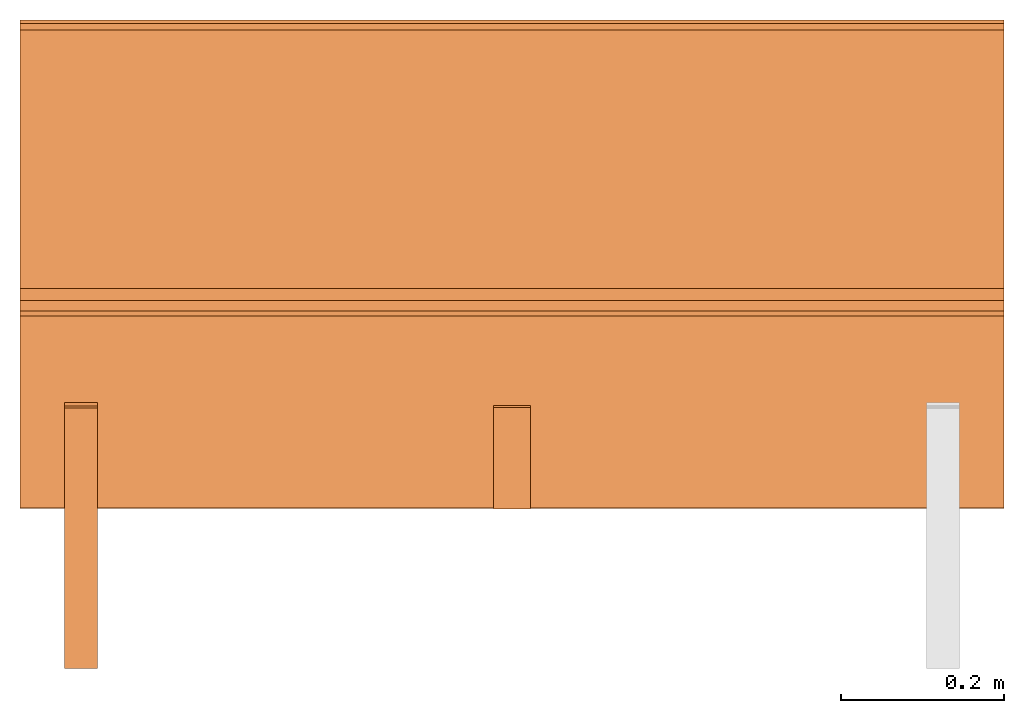
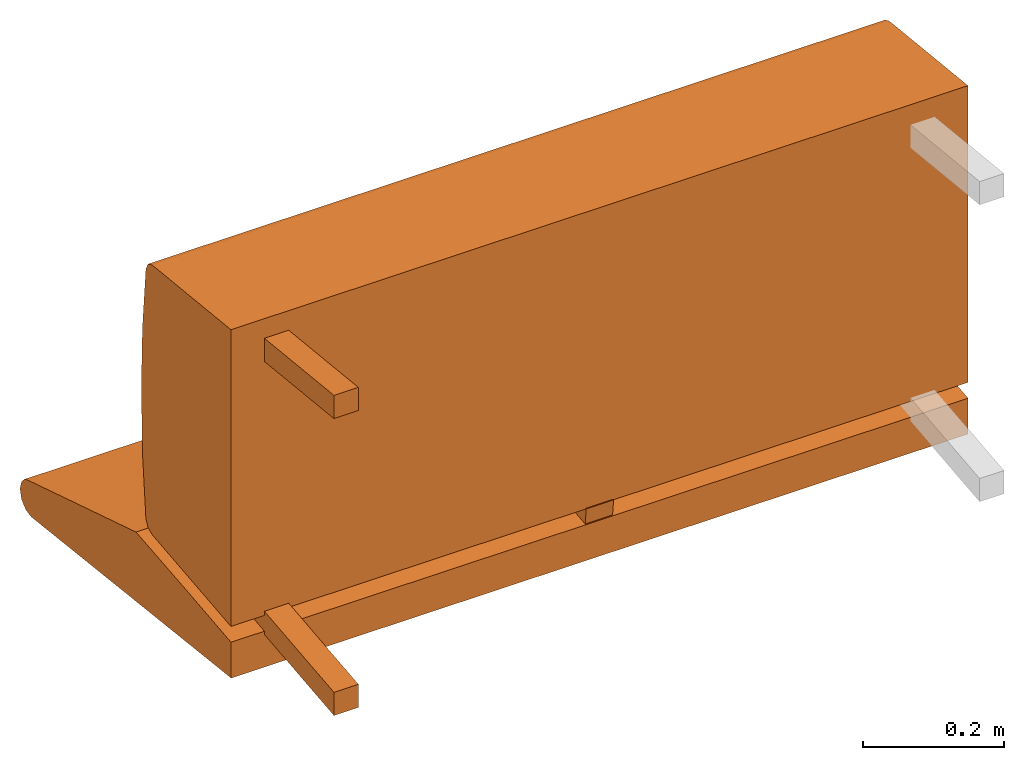
# One storey, part 1 of 2: 5 proxies, 1 element without a shape of its own.
"""IFC2X3 building model written with IfcOpenShell, lengths in metres."""

from ifc_helpers import new_model, si_unit, direction, origin_with_axes, place, context, project, spatial, faceted_brep, source, transform, mapped, element, aggregate, save


model = new_model("IFC2X3")

# Units and contexts
model_context = context("Model", 3, precision=1e-06, world=origin_with_axes(), true_north=direction((0.0, 1.0, 0.0)))
ifc_project = project(units=[si_unit("LENGTHUNIT", "METRE"), si_unit("AREAUNIT", "SQUARE_METRE"), si_unit("VOLUMEUNIT", "CUBIC_METRE")], contexts=[model_context])

# Site, building, storey
site_placement = place(None, origin_with_axes())
site = spatial("IfcSite", under=ifc_project, at=site_placement, CompositionType="ELEMENT")
building_placement = place(site_placement, origin_with_axes())
building = spatial("IfcBuilding", under=site, at=building_placement, Name="Default Building", CompositionType="ELEMENT")
storey_placement = place(building_placement, origin_with_axes())
storey = spatial("IfcBuildingStorey", under=building, at=storey_placement, Name="Default Storey", CompositionType="ELEMENT", Elevation=0.0)

# Assembly, proxies
assembly_placement = place(storey_placement, origin_with_axes())
assembly = element("IfcElementAssembly", 1, at=assembly_placement, inside=storey, AssemblyPlace="NOTDEFINED", PredefinedType="NOTDEFINED")
shared_shape_1 = source(origin_with_axes(), model_context, "Body", "Brep", [
    faceted_brep([(0.6050000190734863, 0.01804635114967823, -0.27114158868789673), (0.6050000190734863, 0.15895022451877594, -0.2573375105857849), (-0.6050000190734863, 0.01804635114967823, -0.27114158868789673), (-0.6050000190734863, 0.01804635114967823, -0.27114158868789673), (0.6050000190734863, 0.15895022451877594, -0.2573375105857849), (-0.6050000190734863, 0.15895022451877594, -0.2573375105857849), (0.6050000190734863, -0.11124149709939957, -0.28473028540611267), (0.6050000190734863, 0.01804635114967823, -0.27114158868789673), (-0.6050000190734863, -0.11124149709939957, -0.28473028540611267), (-0.6050000190734863, -0.11124149709939957, -0.28473028540611267), (0.6050000190734863, 0.01804635114967823, -0.27114158868789673), (-0.6050000190734863, 0.01804635114967823, -0.27114158868789673), (0.6050000190734863, -0.11165377497673035, -0.345802903175354), (0.6050000190734863, -0.11124149709939957, -0.28473028540611267), (-0.6050000190734863, -0.11165377497673035, -0.345802903175354), (-0.6050000190734863, -0.11165377497673035, -0.345802903175354), (0.6050000190734863, -0.11124149709939957, -0.28473028540611267), (-0.6050000190734863, -0.11124149709939957, -0.28473028540611267), (0.6050000190734863, -0.11165299266576767, -0.34598633646965027), (0.6050000190734863, -0.11165377497673035, -0.345802903175354), (-0.6050000190734863, -0.11165299266576767, -0.34598633646965027), (-0.6050000190734863, -0.11165299266576767, -0.34598633646965027), (0.6050000190734863, -0.11165377497673035, -0.345802903175354), (-0.6050000190734863, -0.11165377497673035, -0.345802903175354), (0.6050000190734863, -0.11164932698011398, -0.3461695909500122), (0.6050000190734863, -0.11165299266576767, -0.34598633646965027), (-0.6050000190734863, -0.11164932698011398, -0.3461695909500122), (-0.6050000190734863, -0.11164932698011398, -0.3461695909500122), (0.6050000190734863, -0.11165299266576767, -0.34598633646965027), (-0.6050000190734863, -0.11165299266576767, -0.34598633646965027), (0.6050000190734863, -0.11164313554763794, -0.3463243842124939), (0.6050000190734863, -0.11164932698011398, -0.3461695909500122), (-0.6050000190734863, -0.11164313554763794, -0.3463243842124939), (-0.6050000190734863, -0.11164313554763794, -0.3463243842124939), (0.6050000190734863, -0.11164932698011398, -0.3461695909500122), (-0.6050000190734863, -0.11164932698011398, -0.3461695909500122), (0.6050000190734863, -0.111635722219944, -0.34647393226623535), (0.6050000190734863, -0.11164313554763794, -0.3463243842124939), (-0.6050000190734863, -0.111635722219944, -0.34647393226623535), (-0.6050000190734863, -0.111635722219944, -0.34647393226623535), (0.6050000190734863, -0.11164313554763794, -0.3463243842124939), (-0.6050000190734863, -0.11164313554763794, -0.3463243842124939), (0.6050000190734863, -0.11160843819379807, -0.3467184603214264), (0.6050000190734863, -0.111635722219944, -0.34647393226623535), (-0.6050000190734863, -0.11160843819379807, -0.3467184603214264), (-0.6050000190734863, -0.11160843819379807, -0.3467184603214264), (0.6050000190734863, -0.111635722219944, -0.34647393226623535), (-0.6050000190734863, -0.111635722219944, -0.34647393226623535), (0.6050000190734863, 0.45686498284339905, -0.41162583231925964), (0.6050000190734863, -0.11160843819379807, -0.3467184603214264), (-0.6050000190734863, 0.45686498284339905, -0.41162583231925964), (-0.6050000190734863, 0.45686498284339905, -0.41162583231925964), (0.6050000190734863, -0.11160843819379807, -0.3467184603214264), (-0.6050000190734863, -0.11160843819379807, -0.3467184603214264), (0.6050000190734863, 0.4726467430591583, -0.40858420729637146), (0.6050000190734863, 0.45686498284339905, -0.41162583231925964), (-0.6050000190734863, 0.4726467430591583, -0.40858420729637146), (-0.6050000190734863, 0.4726467430591583, -0.40858420729637146), (0.6050000190734863, 0.45686498284339905, -0.41162583231925964), (-0.6050000190734863, 0.45686498284339905, -0.41162583231925964), (0.6050000190734863, 0.48448991775512695, -0.397742360830307), (0.6050000190734863, 0.4726467430591583, -0.40858420729637146), (-0.6050000190734863, 0.48448991775512695, -0.397742360830307), (-0.6050000190734863, 0.48448991775512695, -0.397742360830307), (0.6050000190734863, 0.4726467430591583, -0.40858420729637146), (-0.6050000190734863, 0.4726467430591583, -0.40858420729637146), (0.6050000190734863, 0.4888731837272644, -0.3822959065437317), (0.6050000190734863, 0.48448991775512695, -0.397742360830307), (-0.6050000190734863, 0.4888731837272644, -0.3822959065437317), (-0.6050000190734863, 0.4888731837272644, -0.3822959065437317), (0.6050000190734863, 0.48448991775512695, -0.397742360830307), (-0.6050000190734863, 0.48448991775512695, -0.397742360830307), (0.6050000190734863, 0.48448991775512695, -0.36684948205947876), (0.6050000190734863, 0.4888731837272644, -0.3822959065437317), (-0.6050000190734863, 0.48448991775512695, -0.36684948205947876), (-0.6050000190734863, 0.48448991775512695, -0.36684948205947876), (0.6050000190734863, 0.4888731837272644, -0.3822959065437317), (-0.6050000190734863, 0.4888731837272644, -0.3822959065437317), (0.6050000190734863, 0.47627729177474976, -0.35816749930381775), (0.6050000190734863, 0.48448991775512695, -0.36684948205947876), (-0.6050000190734863, 0.47627729177474976, -0.35816749930381775), (-0.6050000190734863, 0.47627729177474976, -0.35816749930381775), (0.6050000190734863, 0.48448991775512695, -0.36684948205947876), (-0.6050000190734863, 0.48448991775512695, -0.36684948205947876), (0.6050000190734863, 0.46825650334358215, -0.3542327880859375), (0.6050000190734863, 0.47627729177474976, -0.35816749930381775), (-0.6050000190734863, 0.46825650334358215, -0.3542327880859375), (-0.6050000190734863, 0.46825650334358215, -0.3542327880859375), (0.6050000190734863, 0.47627729177474976, -0.35816749930381775), (-0.6050000190734863, 0.47627729177474976, -0.35816749930381775), (0.6050000190734863, 0.15895022451877594, -0.2573375105857849), (0.6050000190734863, 0.46825650334358215, -0.3542327880859375), (-0.6050000190734863, 0.15895022451877594, -0.2573375105857849), (-0.6050000190734863, 0.15895022451877594, -0.2573375105857849), (0.6050000190734863, 0.46825650334358215, -0.3542327880859375), (-0.6050000190734863, 0.46825650334358215, -0.3542327880859375), (0.6050000190734863, -0.111635722219944, -0.34647393226623535), (0.6050000190734863, -0.11160843819379807, -0.3467184603214264), (0.6050000190734863, 0.01804635114967823, -0.27114158868789673), (0.6050000190734863, 0.45686498284339905, -0.41162583231925964), (0.6050000190734863, 0.46825650334358215, -0.3542327880859375), (0.6050000190734863, -0.11160843819379807, -0.3467184603214264), (0.6050000190734863, -0.11160843819379807, -0.3467184603214264), (0.6050000190734863, 0.46825650334358215, -0.3542327880859375), (0.6050000190734863, 0.15895022451877594, -0.2573375105857849), (0.6050000190734863, -0.11160843819379807, -0.3467184603214264), (0.6050000190734863, 0.15895022451877594, -0.2573375105857849), (0.6050000190734863, 0.01804635114967823, -0.27114158868789673), (0.6050000190734863, -0.11124149709939957, -0.28473028540611267), (0.6050000190734863, -0.11165377497673035, -0.345802903175354), (0.6050000190734863, 0.01804635114967823, -0.27114158868789673), (0.6050000190734863, 0.01804635114967823, -0.27114158868789673), (0.6050000190734863, -0.11165377497673035, -0.345802903175354), (0.6050000190734863, -0.11165299266576767, -0.34598633646965027), (0.6050000190734863, -0.11165299266576767, -0.34598633646965027), (0.6050000190734863, -0.11164932698011398, -0.3461695909500122), (0.6050000190734863, 0.01804635114967823, -0.27114158868789673), (0.6050000190734863, 0.01804635114967823, -0.27114158868789673), (0.6050000190734863, -0.11164932698011398, -0.3461695909500122), (0.6050000190734863, -0.11164313554763794, -0.3463243842124939), (0.6050000190734863, 0.01804635114967823, -0.27114158868789673), (0.6050000190734863, -0.11164313554763794, -0.3463243842124939), (0.6050000190734863, -0.111635722219944, -0.34647393226623535), (0.6050000190734863, 0.48448991775512695, -0.397742360830307), (0.6050000190734863, 0.4888731837272644, -0.3822959065437317), (0.6050000190734863, 0.4726467430591583, -0.40858420729637146), (0.6050000190734863, 0.4726467430591583, -0.40858420729637146), (0.6050000190734863, 0.4888731837272644, -0.3822959065437317), (0.6050000190734863, 0.48448991775512695, -0.36684948205947876), (0.6050000190734863, 0.4726467430591583, -0.40858420729637146), (0.6050000190734863, 0.48448991775512695, -0.36684948205947876), (0.6050000190734863, 0.45686498284339905, -0.41162583231925964), (0.6050000190734863, 0.45686498284339905, -0.41162583231925964), (0.6050000190734863, 0.48448991775512695, -0.36684948205947876), (0.6050000190734863, 0.47627729177474976, -0.35816749930381775), (0.6050000190734863, 0.45686498284339905, -0.41162583231925964), (0.6050000190734863, 0.47627729177474976, -0.35816749930381775), (0.6050000190734863, 0.46825650334358215, -0.3542327880859375), (-0.6050000190734863, -0.11165377497673035, -0.345802903175354), (-0.6050000190734863, -0.11124149709939957, -0.28473028540611267), (-0.6050000190734863, 0.01804635114967823, -0.27114158868789673), (-0.6050000190734863, 0.46825650334358215, -0.3542327880859375), (-0.6050000190734863, 0.45686498284339905, -0.41162583231925964), (-0.6050000190734863, 0.15895022451877594, -0.2573375105857849), (-0.6050000190734863, 0.15895022451877594, -0.2573375105857849), (-0.6050000190734863, 0.45686498284339905, -0.41162583231925964), (-0.6050000190734863, -0.11160843819379807, -0.3467184603214264), (-0.6050000190734863, 0.15895022451877594, -0.2573375105857849), (-0.6050000190734863, -0.11160843819379807, -0.3467184603214264), (-0.6050000190734863, 0.01804635114967823, -0.27114158868789673), (-0.6050000190734863, 0.01804635114967823, -0.27114158868789673), (-0.6050000190734863, -0.11160843819379807, -0.3467184603214264), (-0.6050000190734863, -0.111635722219944, -0.34647393226623535), (-0.6050000190734863, 0.01804635114967823, -0.27114158868789673), (-0.6050000190734863, -0.111635722219944, -0.34647393226623535), (-0.6050000190734863, -0.11164313554763794, -0.3463243842124939), (-0.6050000190734863, -0.11164313554763794, -0.3463243842124939), (-0.6050000190734863, -0.11164932698011398, -0.3461695909500122), (-0.6050000190734863, 0.01804635114967823, -0.27114158868789673), (-0.6050000190734863, 0.01804635114967823, -0.27114158868789673), (-0.6050000190734863, -0.11164932698011398, -0.3461695909500122), (-0.6050000190734863, -0.11165299266576767, -0.34598633646965027), (-0.6050000190734863, 0.01804635114967823, -0.27114158868789673), (-0.6050000190734863, -0.11165299266576767, -0.34598633646965027), (-0.6050000190734863, -0.11165377497673035, -0.345802903175354), (-0.6050000190734863, 0.48448991775512695, -0.36684948205947876), (-0.6050000190734863, 0.4888731837272644, -0.3822959065437317), (-0.6050000190734863, 0.48448991775512695, -0.397742360830307), (-0.6050000190734863, 0.46825650334358215, -0.3542327880859375), (-0.6050000190734863, 0.47627729177474976, -0.35816749930381775), (-0.6050000190734863, 0.45686498284339905, -0.41162583231925964), (-0.6050000190734863, 0.45686498284339905, -0.41162583231925964), (-0.6050000190734863, 0.47627729177474976, -0.35816749930381775), (-0.6050000190734863, 0.48448991775512695, -0.36684948205947876), (-0.6050000190734863, 0.45686498284339905, -0.41162583231925964), (-0.6050000190734863, 0.48448991775512695, -0.36684948205947876), (-0.6050000190734863, 0.4726467430591583, -0.40858420729637146), (-0.6050000190734863, 0.4726467430591583, -0.40858420729637146), (-0.6050000190734863, 0.48448991775512695, -0.36684948205947876), (-0.6050000190734863, 0.48448991775512695, -0.397742360830307)], [[[0, 1, 2]], [[3, 4, 5]], [[6, 7, 8]], [[9, 10, 11]], [[12, 13, 14]], [[15, 16, 17]], [[18, 19, 20]], [[21, 22, 23]], [[24, 25, 26]], [[27, 28, 29]], [[30, 31, 32]], [[33, 34, 35]], [[36, 37, 38]], [[39, 40, 41]], [[42, 43, 44]], [[45, 46, 47]], [[48, 49, 50]], [[51, 52, 53]], [[54, 55, 56]], [[57, 58, 59]], [[60, 61, 62]], [[63, 64, 65]], [[66, 67, 68]], [[69, 70, 71]], [[72, 73, 74]], [[75, 76, 77]], [[78, 79, 80]], [[81, 82, 83]], [[84, 85, 86]], [[87, 88, 89]], [[90, 91, 92]], [[93, 94, 95]], [[96, 97, 98]], [[99, 100, 101]], [[102, 103, 104]], [[105, 106, 107]], [[108, 109, 110]], [[111, 112, 113]], [[114, 115, 116]], [[117, 118, 119]], [[120, 121, 122]], [[123, 124, 125]], [[126, 127, 128]], [[129, 130, 131]], [[132, 133, 134]], [[135, 136, 137]], [[138, 139, 140]], [[141, 142, 143]], [[144, 145, 146]], [[147, 148, 149]], [[150, 151, 152]], [[153, 154, 155]], [[156, 157, 158]], [[159, 160, 161]], [[162, 163, 164]], [[165, 166, 167]], [[168, 169, 170]], [[171, 172, 173]], [[174, 175, 176]], [[177, 178, 179]]]),
])
proxy_1_placement = place(assembly_placement, origin_with_axes())
proxy_1 = element("IfcBuildingElementProxy", 2, at=proxy_1_placement, Name="1", ObjectType="1", CompositionType="ELEMENT", context=model_context, shape_type="MappedRepresentation", body=[
    mapped(shared_shape_1, transform((0.0, 0.0, 0.0), scale=1.0)),
])
shared_shape_2 = source(origin_with_axes(), model_context, "Body", "Brep", [
    faceted_brep([(0.6050000190734863, -0.11101193726062775, -0.2574460208415985), (0.6050000190734863, -0.11100000143051147, 0.25755399465560913), (-0.6050000190734863, -0.11101193726062775, -0.2574460208415985), (-0.6050000190734863, -0.11101193726062775, -0.2574460208415985), (0.6050000190734863, -0.11100000143051147, 0.25755399465560913), (-0.6050000190734863, -0.11100000143051147, 0.25755399465560913), (0.6050000190734863, 0.11315424740314484, -0.23389045894145966), (0.6050000190734863, -0.11101193726062775, -0.2574460208415985), (-0.6050000190734863, 0.11315424740314484, -0.23389045894145966), (-0.6050000190734863, 0.11315424740314484, -0.23389045894145966), (0.6050000190734863, -0.11101193726062775, -0.2574460208415985), (-0.6050000190734863, -0.11101193726062775, -0.2574460208415985), (0.6050000190734863, 0.12509645521640778, -0.22825108468532562), (0.6050000190734863, 0.11315424740314484, -0.23389045894145966), (-0.6050000190734863, 0.12509645521640778, -0.22825108468532562), (-0.6050000190734863, 0.12509645521640778, -0.22825108468532562), (0.6050000190734863, 0.11315424740314484, -0.23389045894145966), (-0.6050000190734863, 0.11315424740314484, -0.23389045894145966), (0.6050000190734863, 0.1309199035167694, -0.21639753878116608), (0.6050000190734863, 0.12509645521640778, -0.22825108468532562), (-0.6050000190734863, 0.1309199035167694, -0.21639753878116608), (-0.6050000190734863, 0.1309199035167694, -0.21639753878116608), (0.6050000190734863, 0.12509645521640778, -0.22825108468532562), (-0.6050000190734863, 0.12509645521640778, -0.22825108468532562), (0.6050000190734863, 0.1406860649585724, -0.10837232321500778), (0.6050000190734863, 0.1309199035167694, -0.21639753878116608), (-0.6050000190734863, 0.1406860649585724, -0.10837232321500778), (-0.6050000190734863, 0.1406860649585724, -0.10837232321500778), (0.6050000190734863, 0.1309199035167694, -0.21639753878116608), (-0.6050000190734863, 0.1309199035167694, -0.21639753878116608), (0.6050000190734863, 0.1439555585384369, 4.417426316649653e-05), (0.6050000190734863, 0.1406860649585724, -0.10837232321500778), (-0.6050000190734863, 0.1439555585384369, 4.417426316649653e-05), (-0.6050000190734863, 0.1439555585384369, 4.417426316649653e-05), (0.6050000190734863, 0.1406860649585724, -0.10837232321500778), (-0.6050000190734863, 0.1406860649585724, -0.10837232321500778), (0.6050000190734863, 0.14071664214134216, 0.10846158862113953), (0.6050000190734863, 0.1439555585384369, 4.417426316649653e-05), (-0.6050000190734863, 0.14071664214134216, 0.10846158862113953), (-0.6050000190734863, 0.14071664214134216, 0.10846158862113953), (0.6050000190734863, 0.1439555585384369, 4.417426316649653e-05), (-0.6050000190734863, 0.1439555585384369, 4.417426316649653e-05), (0.6050000190734863, 0.1309809684753418, 0.21648956835269928), (0.6050000190734863, 0.14071664214134216, 0.10846158862113953), (-0.6050000190734863, 0.1309809684753418, 0.21648956835269928), (-0.6050000190734863, 0.1309809684753418, 0.21648956835269928), (0.6050000190734863, 0.14071664214134216, 0.10846158862113953), (-0.6050000190734863, 0.14071664214134216, 0.10846158862113953), (0.6050000190734863, 0.12515902519226074, 0.2283465564250946), (0.6050000190734863, 0.1309809684753418, 0.21648956835269928), (-0.6050000190734863, 0.12515902519226074, 0.2283465564250946), (-0.6050000190734863, 0.12515902519226074, 0.2283465564250946), (0.6050000190734863, 0.1309809684753418, 0.21648956835269928), (-0.6050000190734863, 0.1309809684753418, 0.21648956835269928), (0.6050000190734863, 0.11321509629487991, 0.23398803174495697), (0.6050000190734863, 0.12515902519226074, 0.2283465564250946), (-0.6050000190734863, 0.11321509629487991, 0.23398803174495697), (-0.6050000190734863, 0.11321509629487991, 0.23398803174495697), (0.6050000190734863, 0.12515902519226074, 0.2283465564250946), (-0.6050000190734863, 0.12515902519226074, 0.2283465564250946), (0.6050000190734863, -0.11100000143051147, 0.25755399465560913), (0.6050000190734863, 0.11321509629487991, 0.23398803174495697), (-0.6050000190734863, -0.11100000143051147, 0.25755399465560913), (-0.6050000190734863, -0.11100000143051147, 0.25755399465560913), (0.6050000190734863, 0.11321509629487991, 0.23398803174495697), (-0.6050000190734863, 0.11321509629487991, 0.23398803174495697), (0.6050000190734863, 0.1309809684753418, 0.21648956835269928), (0.6050000190734863, 0.12515902519226074, 0.2283465564250946), (0.6050000190734863, 0.14071664214134216, 0.10846158862113953), (0.6050000190734863, 0.14071664214134216, 0.10846158862113953), (0.6050000190734863, 0.12515902519226074, 0.2283465564250946), (0.6050000190734863, 0.11321509629487991, 0.23398803174495697), (0.6050000190734863, 0.14071664214134216, 0.10846158862113953), (0.6050000190734863, 0.11321509629487991, 0.23398803174495697), (0.6050000190734863, -0.11100000143051147, 0.25755399465560913), (0.6050000190734863, 0.12509645521640778, -0.22825108468532562), (0.6050000190734863, 0.1309199035167694, -0.21639753878116608), (0.6050000190734863, 0.11315424740314484, -0.23389045894145966), (0.6050000190734863, 0.11315424740314484, -0.23389045894145966), (0.6050000190734863, 0.1309199035167694, -0.21639753878116608), (0.6050000190734863, 0.1406860649585724, -0.10837232321500778), (0.6050000190734863, 0.11315424740314484, -0.23389045894145966), (0.6050000190734863, 0.1406860649585724, -0.10837232321500778), (0.6050000190734863, -0.11101193726062775, -0.2574460208415985), (0.6050000190734863, -0.11101193726062775, -0.2574460208415985), (0.6050000190734863, 0.1406860649585724, -0.10837232321500778), (0.6050000190734863, -0.11100000143051147, 0.25755399465560913), (0.6050000190734863, -0.11100000143051147, 0.25755399465560913), (0.6050000190734863, 0.1406860649585724, -0.10837232321500778), (0.6050000190734863, 0.1439555585384369, 4.417426316649653e-05), (0.6050000190734863, -0.11100000143051147, 0.25755399465560913), (0.6050000190734863, 0.1439555585384369, 4.417426316649653e-05), (0.6050000190734863, 0.14071664214134216, 0.10846158862113953), (-0.6050000190734863, 0.1406860649585724, -0.10837232321500778), (-0.6050000190734863, 0.1309199035167694, -0.21639753878116608), (-0.6050000190734863, 0.12509645521640778, -0.22825108468532562), (-0.6050000190734863, 0.12515902519226074, 0.2283465564250946), (-0.6050000190734863, 0.1309809684753418, 0.21648956835269928), (-0.6050000190734863, 0.11321509629487991, 0.23398803174495697), (-0.6050000190734863, 0.11321509629487991, 0.23398803174495697), (-0.6050000190734863, 0.1309809684753418, 0.21648956835269928), (-0.6050000190734863, 0.14071664214134216, 0.10846158862113953), (-0.6050000190734863, 0.11321509629487991, 0.23398803174495697), (-0.6050000190734863, 0.14071664214134216, 0.10846158862113953), (-0.6050000190734863, -0.11100000143051147, 0.25755399465560913), (-0.6050000190734863, -0.11100000143051147, 0.25755399465560913), (-0.6050000190734863, 0.14071664214134216, 0.10846158862113953), (-0.6050000190734863, 0.1439555585384369, 4.417426316649653e-05), (-0.6050000190734863, -0.11100000143051147, 0.25755399465560913), (-0.6050000190734863, 0.1439555585384369, 4.417426316649653e-05), (-0.6050000190734863, -0.11101193726062775, -0.2574460208415985), (-0.6050000190734863, -0.11101193726062775, -0.2574460208415985), (-0.6050000190734863, 0.1439555585384369, 4.417426316649653e-05), (-0.6050000190734863, 0.1406860649585724, -0.10837232321500778), (-0.6050000190734863, -0.11101193726062775, -0.2574460208415985), (-0.6050000190734863, 0.1406860649585724, -0.10837232321500778), (-0.6050000190734863, 0.11315424740314484, -0.23389045894145966), (-0.6050000190734863, 0.11315424740314484, -0.23389045894145966), (-0.6050000190734863, 0.1406860649585724, -0.10837232321500778), (-0.6050000190734863, 0.12509645521640778, -0.22825108468532562)], [[[0, 1, 2]], [[3, 4, 5]], [[6, 7, 8]], [[9, 10, 11]], [[12, 13, 14]], [[15, 16, 17]], [[18, 19, 20]], [[21, 22, 23]], [[24, 25, 26]], [[27, 28, 29]], [[30, 31, 32]], [[33, 34, 35]], [[36, 37, 38]], [[39, 40, 41]], [[42, 43, 44]], [[45, 46, 47]], [[48, 49, 50]], [[51, 52, 53]], [[54, 55, 56]], [[57, 58, 59]], [[60, 61, 62]], [[63, 64, 65]], [[66, 67, 68]], [[69, 70, 71]], [[72, 73, 74]], [[75, 76, 77]], [[78, 79, 80]], [[81, 82, 83]], [[84, 85, 86]], [[87, 88, 89]], [[90, 91, 92]], [[93, 94, 95]], [[96, 97, 98]], [[99, 100, 101]], [[102, 103, 104]], [[105, 106, 107]], [[108, 109, 110]], [[111, 112, 113]], [[114, 115, 116]], [[117, 118, 119]]]),
])
proxy_2_placement = place(assembly_placement, origin_with_axes())
proxy_2 = element("IfcBuildingElementProxy", 3, at=proxy_2_placement, Name="3", ObjectType="3", CompositionType="ELEMENT", context=model_context, shape_type="MappedRepresentation", body=[
    mapped(shared_shape_2, transform((0.0, 0.0, 0.0), scale=1.0)),
])
shared_shape_3 = source(origin_with_axes(), model_context, "Body", "Brep", [
    faceted_brep([(-0.5099999904632568, -0.3086836636066437, 0.203923761844635), (-0.5099999904632568, -0.3086836636066437, 0.24414409697055817), (-0.550000011920929, -0.3086836636066437, 0.203923761844635), (-0.550000011920929, -0.3086836636066437, 0.203923761844635), (-0.5099999904632568, -0.3086836636066437, 0.24414409697055817), (-0.550000011920929, -0.3086836636066437, 0.24414409697055817), (-0.5099999904632568, 0.00747277494519949, 0.17069438099861145), (-0.5099999904632568, -0.3086836636066437, 0.203923761844635), (-0.550000011920929, 0.00747277494519949, 0.17069438099861145), (-0.550000011920929, 0.00747277494519949, 0.17069438099861145), (-0.5099999904632568, -0.3086836636066437, 0.203923761844635), (-0.550000011920929, -0.3086836636066437, 0.203923761844635), (-0.5099999904632568, 0.011653914116322994, 0.21047525107860565), (-0.5099999904632568, 0.00747277494519949, 0.17069438099861145), (-0.550000011920929, 0.011653914116322994, 0.21047525107860565), (-0.550000011920929, 0.011653914116322994, 0.21047525107860565), (-0.5099999904632568, 0.00747277494519949, 0.17069438099861145), (-0.550000011920929, 0.00747277494519949, 0.17069438099861145), (-0.5099999904632568, -0.3086836636066437, 0.24414409697055817), (-0.5099999904632568, 0.011653914116322994, 0.21047525107860565), (-0.550000011920929, -0.3086836636066437, 0.24414409697055817), (-0.550000011920929, -0.3086836636066437, 0.24414409697055817), (-0.5099999904632568, 0.011653914116322994, 0.21047525107860565), (-0.550000011920929, 0.011653914116322994, 0.21047525107860565), (-0.5099999904632568, 0.00747277494519949, 0.17069438099861145), (-0.5099999904632568, 0.011653914116322994, 0.21047525107860565), (-0.5099999904632568, -0.3086836636066437, 0.203923761844635), (-0.5099999904632568, -0.3086836636066437, 0.203923761844635), (-0.5099999904632568, 0.011653914116322994, 0.21047525107860565), (-0.5099999904632568, -0.3086836636066437, 0.24414409697055817), (-0.550000011920929, 0.011653914116322994, 0.21047525107860565), (-0.550000011920929, 0.00747277494519949, 0.17069438099861145), (-0.550000011920929, -0.3086836636066437, 0.24414409697055817), (-0.550000011920929, -0.3086836636066437, 0.24414409697055817), (-0.550000011920929, 0.00747277494519949, 0.17069438099861145), (-0.550000011920929, -0.3086836636066437, 0.203923761844635)], [[[0, 1, 2]], [[3, 4, 5]], [[6, 7, 8]], [[9, 10, 11]], [[12, 13, 14]], [[15, 16, 17]], [[18, 19, 20]], [[21, 22, 23]], [[24, 25, 26]], [[27, 28, 29]], [[30, 31, 32]], [[33, 34, 35]]]),
])
proxy_3_placement = place(assembly_placement, origin_with_axes())
proxy_3 = element("IfcBuildingElementProxy", 4, at=proxy_3_placement, Name="6", ObjectType="6", CompositionType="ELEMENT", context=model_context, shape_type="MappedRepresentation", body=[
    mapped(shared_shape_3, transform((0.0, 0.0, 0.0), scale=1.0)),
])
shared_shape_4 = source(origin_with_axes(), model_context, "Body", "Brep", [
    faceted_brep([(-0.5099999904632568, -0.3086836636066437, -0.2712950110435486), (-0.5099999904632568, 0.014434427954256535, -0.23733393847942352), (-0.550000011920929, -0.3086836636066437, -0.2712950110435486), (-0.550000011920929, -0.3086836636066437, -0.2712950110435486), (-0.5099999904632568, 0.014434427954256535, -0.23733393847942352), (-0.550000011920929, 0.014434427954256535, -0.23733393847942352), (-0.5099999904632568, -0.3086836636066437, -0.31151533126831055), (-0.5099999904632568, -0.3086836636066437, -0.2712950110435486), (-0.550000011920929, -0.3086836636066437, -0.31151533126831055), (-0.550000011920929, -0.3086836636066437, -0.31151533126831055), (-0.5099999904632568, -0.3086836636066437, -0.2712950110435486), (-0.550000011920929, -0.3086836636066437, -0.2712950110435486), (-0.5099999904632568, 0.018615566194057465, -0.2771148085594177), (-0.5099999904632568, -0.3086836636066437, -0.31151533126831055), (-0.550000011920929, 0.018615566194057465, -0.2771148085594177), (-0.550000011920929, 0.018615566194057465, -0.2771148085594177), (-0.5099999904632568, -0.3086836636066437, -0.31151533126831055), (-0.550000011920929, -0.3086836636066437, -0.31151533126831055), (-0.5099999904632568, 0.014434427954256535, -0.23733393847942352), (-0.5099999904632568, 0.018615566194057465, -0.2771148085594177), (-0.550000011920929, 0.014434427954256535, -0.23733393847942352), (-0.550000011920929, 0.014434427954256535, -0.23733393847942352), (-0.5099999904632568, 0.018615566194057465, -0.2771148085594177), (-0.550000011920929, 0.018615566194057465, -0.2771148085594177), (-0.5099999904632568, -0.3086836636066437, -0.31151533126831055), (-0.5099999904632568, 0.018615566194057465, -0.2771148085594177), (-0.5099999904632568, -0.3086836636066437, -0.2712950110435486), (-0.5099999904632568, -0.3086836636066437, -0.2712950110435486), (-0.5099999904632568, 0.018615566194057465, -0.2771148085594177), (-0.5099999904632568, 0.014434427954256535, -0.23733393847942352), (-0.550000011920929, 0.018615566194057465, -0.2771148085594177), (-0.550000011920929, -0.3086836636066437, -0.31151533126831055), (-0.550000011920929, 0.014434427954256535, -0.23733393847942352), (-0.550000011920929, 0.014434427954256535, -0.23733393847942352), (-0.550000011920929, -0.3086836636066437, -0.31151533126831055), (-0.550000011920929, -0.3086836636066437, -0.2712950110435486)], [[[0, 1, 2]], [[3, 4, 5]], [[6, 7, 8]], [[9, 10, 11]], [[12, 13, 14]], [[15, 16, 17]], [[18, 19, 20]], [[21, 22, 23]], [[24, 25, 26]], [[27, 28, 29]], [[30, 31, 32]], [[33, 34, 35]]]),
])
proxy_4_placement = place(assembly_placement, origin_with_axes())
proxy_4 = element("IfcBuildingElementProxy", 5, at=proxy_4_placement, Name="7", ObjectType="7", CompositionType="ELEMENT", context=model_context, shape_type="MappedRepresentation", body=[
    mapped(shared_shape_4, transform((0.0, 0.0, 0.0), scale=1.0)),
])
shared_shape_5 = source(origin_with_axes(), model_context, "Body", "Brep", [
    faceted_brep([(-0.02250000089406967, -0.10928957164287567, -0.2845251262187958), (-0.02250000089406967, 0.015025665983557701, -0.27145907282829285), (0.02250000089406967, -0.10928957164287567, -0.2845251262187958), (0.02250000089406967, -0.10928957164287567, -0.2845251262187958), (-0.02250000089406967, 0.015025665983557701, -0.27145907282829285), (0.02250000089406967, 0.015025665983557701, -0.27145907282829285), (-0.02250000089406967, -0.11221636831760406, -0.2566785216331482), (-0.02250000089406967, -0.10928957164287567, -0.2845251262187958), (0.02250000089406967, -0.11221636831760406, -0.2566785216331482), (0.02250000089406967, -0.11221636831760406, -0.2566785216331482), (-0.02250000089406967, -0.10928957164287567, -0.2845251262187958), (0.02250000089406967, -0.10928957164287567, -0.2845251262187958), (-0.02250000089406967, 0.012098868377506733, -0.24361246824264526), (-0.02250000089406967, -0.11221636831760406, -0.2566785216331482), (0.02250000089406967, 0.012098868377506733, -0.24361246824264526), (0.02250000089406967, 0.012098868377506733, -0.24361246824264526), (-0.02250000089406967, -0.11221636831760406, -0.2566785216331482), (0.02250000089406967, -0.11221636831760406, -0.2566785216331482), (-0.02250000089406967, 0.015025665983557701, -0.27145907282829285), (-0.02250000089406967, 0.012098868377506733, -0.24361246824264526), (0.02250000089406967, 0.015025665983557701, -0.27145907282829285), (0.02250000089406967, 0.015025665983557701, -0.27145907282829285), (-0.02250000089406967, 0.012098868377506733, -0.24361246824264526), (0.02250000089406967, 0.012098868377506733, -0.24361246824264526), (-0.02250000089406967, -0.11221636831760406, -0.2566785216331482), (-0.02250000089406967, 0.012098868377506733, -0.24361246824264526), (-0.02250000089406967, -0.10928957164287567, -0.2845251262187958), (-0.02250000089406967, -0.10928957164287567, -0.2845251262187958), (-0.02250000089406967, 0.012098868377506733, -0.24361246824264526), (-0.02250000089406967, 0.015025665983557701, -0.27145907282829285), (0.02250000089406967, 0.012098868377506733, -0.24361246824264526), (0.02250000089406967, -0.11221636831760406, -0.2566785216331482), (0.02250000089406967, 0.015025665983557701, -0.27145907282829285), (0.02250000089406967, 0.015025665983557701, -0.27145907282829285), (0.02250000089406967, -0.11221636831760406, -0.2566785216331482), (0.02250000089406967, -0.10928957164287567, -0.2845251262187958)], [[[0, 1, 2]], [[3, 4, 5]], [[6, 7, 8]], [[9, 10, 11]], [[12, 13, 14]], [[15, 16, 17]], [[18, 19, 20]], [[21, 22, 23]], [[24, 25, 26]], [[27, 28, 29]], [[30, 31, 32]], [[33, 34, 35]]]),
])
proxy_5_placement = place(assembly_placement, origin_with_axes())
proxy_5 = element("IfcBuildingElementProxy", 6, at=proxy_5_placement, Name="9", ObjectType="9", CompositionType="ELEMENT", context=model_context, shape_type="MappedRepresentation", body=[
    mapped(shared_shape_5, transform((0.0, 0.0, 0.0), scale=1.0)),
])
aggregate(assembly, [proxy_1, proxy_2, proxy_3, proxy_4, proxy_5])

save(model, "model.ifc")
